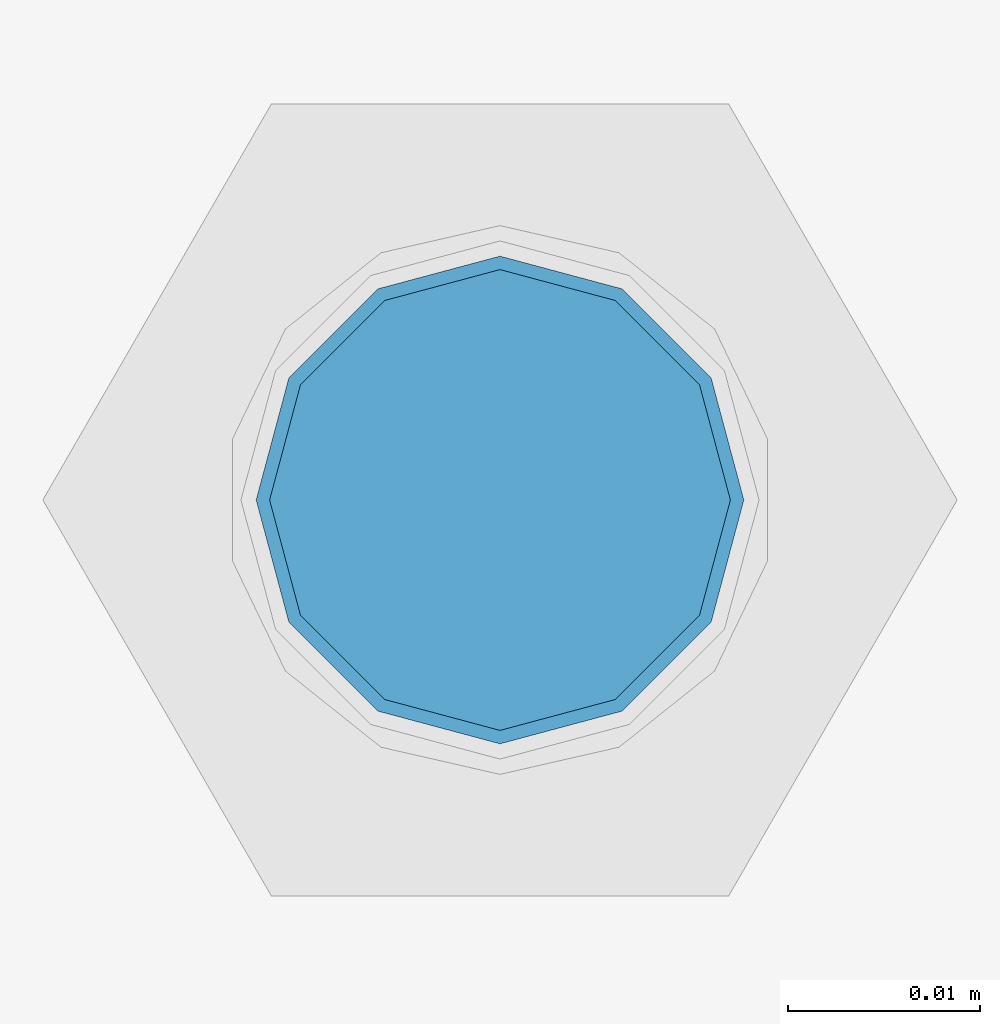
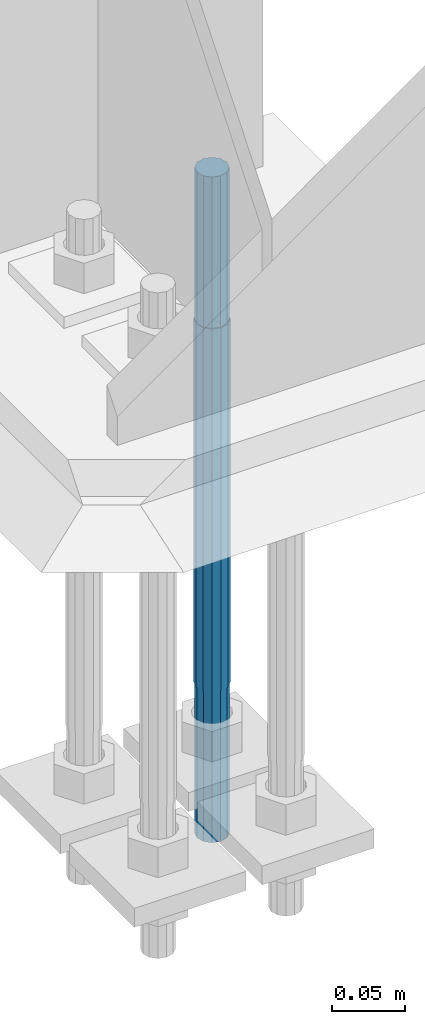
# One storey, part 1602 of 3843: 1 column, 1 element without a shape of its own.
"""IFC2X3 building model written with IfcOpenShell, lengths in millimetres."""

from ifc_helpers import new_model, si_unit, frame, origin_with_axes, place, context, subcontext, project, spatial, faceted_brep, material, type_object, element, aggregate, save


model = new_model("IFC2X3")

# Units and contexts
model_context = context("Model", 3, precision=1e-05, world=origin_with_axes())
body_context = subcontext(model_context, "Body", "Model", "MODEL_VIEW")
ifc_project = project(units=[si_unit("LENGTHUNIT", "METRE", prefix="MILLI"), si_unit("AREAUNIT", "SQUARE_METRE"), si_unit("VOLUMEUNIT", "CUBIC_METRE"), si_unit("MASSUNIT", "GRAM", prefix="KILO"), si_unit("TIMEUNIT", "SECOND"), si_unit("PLANEANGLEUNIT", "RADIAN"), si_unit("SOLIDANGLEUNIT", "STERADIAN"), si_unit("THERMODYNAMICTEMPERATUREUNIT", "DEGREE_CELSIUS"), si_unit("LUMINOUSINTENSITYUNIT", "LUMEN")], contexts=[model_context])

# Site, building, storey
site_placement = place(None, origin_with_axes())
site = spatial("IfcSite", under=ifc_project, at=site_placement, CompositionType="ELEMENT")
building_placement = place(site_placement, origin_with_axes())
building = spatial("IfcBuilding", under=site, at=building_placement, Name="Undefined", CompositionType="ELEMENT")
storey_placement = place(building_placement, origin_with_axes())
storey = spatial("IfcBuildingStorey", under=building, at=storey_placement, Name="Undefined", CompositionType="ELEMENT", Elevation=0.0)

# Assembly, column
assembly_placement = place(storey_placement, origin_with_axes())
assembly = element("IfcElementAssembly", 1, at=assembly_placement, inside=storey, Name="TEMPLATE", AssemblyPlace="NOTDEFINED", PredefinedType="RIGID_FRAME")
ifc_material = material(Name="Undefined/F1554-GR.55")
column_type = type_object("IfcColumnType", PredefinedType="NOTDEFINED")
column_placement = place(assembly_placement, frame((42113.2, 104609.9, 30022.8), z_axis=(0.0, 1.0, 0.0), x_axis=(0.0, 0.0, -1.0)))
column = element("IfcColumn", 2, at=column_placement, type_object=column_type, material=ifc_material, Name="ANCHOR_ROD", context=body_context, shape_type="Brep", body=[
    faceted_brep([(-127.0, -10.3923048454162, 6.0), (-127.0, -6.0, 10.3923048454126), (-127.0, 0.0, 12.0), (-127.0, 6.0, 10.3923048454126), (-127.0, 10.3923048454162, 6.0), (-127.0, 12.0, 0.0), (-127.0, 10.3923048454162, -6.0), (-127.0, 6.0, -10.3923048454126), (-127.0, 0.0, -12.0), (-127.0, -6.0, -10.3923048454126), (-127.0, -10.3923048454162, -6.0), (-127.0, -12.0, 0.0), (0.0, 12.0, 0.0), (0.0, 10.3923048454162, -6.0), (0.0, 6.0, -10.3923048454126), (0.0, 0.0, -12.0), (0.0, -6.0, -10.3923048454126), (0.0, -10.3923048454162, -6.0), (0.0, -12.0, 0.0), (0.0, -10.3923048454162, 6.0), (0.0, -6.0, 10.3923048454126), (0.0, 0.0, 12.0), (0.0, 6.0, 10.3923048454126), (0.0, 10.3923048454162, 6.0), (0.0, -10.9985226280696, 6.34999999999854), (0.0, -6.35000000000582, 10.9985226280623), (0.0, 0.0, 12.6999999999971), (0.0, 6.35000000000582, 10.9985226280623), (0.0, 10.9985226280696, 6.34999999999854), (0.0, 12.6999999999971, 0.0), (0.0, 10.9985226280696, -6.34999999999854), (0.0, 6.35000000000582, -10.9985226280623), (0.0, 0.0, -12.6999999999971), (0.0, -6.35000000000582, -10.9985226280623), (0.0, -10.9985226280696, -6.34999999999854), (0.0, -12.6999999999971, 0.0), (304.799999999999, -12.6999999999971, 0.0), (304.799999999999, -10.9985226280623, 6.35000000000036), (304.799999999999, -6.34999999999854, 10.9985226280623), (304.799999999999, 0.0, 12.7000000000007), (304.799999999999, 6.34999999999854, 10.9985226280623), (304.799999999999, 10.9985226280623, 6.35000000000036), (304.799999999999, 12.6999999999971, 0.0), (304.799999999999, 10.9985226280623, -6.35000000000036), (304.799999999999, 6.34999999999854, -10.9985226280623), (304.799999999999, 0.0, -12.7000000000007), (304.799999999999, -6.34999999999854, -10.9985226280623), (304.799999999999, -10.9985226280623, -6.35000000000036), (304.799999999999, -6.0, 10.3923048454126), (304.799999999999, 0.0, 12.0), (304.799999999999, 6.0, 10.3923048454126), (304.799999999999, 10.3923048454162, 6.0), (304.799999999999, 12.0, 0.0), (304.799999999999, 10.3923048454162, -6.0), (304.799999999999, 6.0, -10.3923048454126), (304.799999999999, 0.0, -12.0), (304.799999999999, -6.0, -10.3923048454126), (304.799999999999, -10.3923048454162, -6.0), (304.799999999999, -12.0, 0.0), (304.799999999999, -10.3923048454162, 6.0), (431.799999999999, -6.0, -10.3923048454126), (431.799999999999, 0.0, -12.0), (431.799999999999, 6.0, -10.3923048454126), (431.799999999999, 10.3923048454162, -6.0), (431.799999999999, 12.0, 0.0), (431.799999999999, 10.3923048454162, 6.0), (431.799999999999, 6.0, 10.3923048454126), (431.799999999999, 0.0, 12.0), (431.799999999999, -6.0, 10.3923048454126), (431.799999999999, -10.3923048454162, 6.0), (431.799999999999, -12.0, 0.0), (431.799999999999, -10.3923048454162, -6.0)], [[[0, 1, 2, 3, 4, 5, 6, 7, 8, 9, 10, 11]], [[6, 5, 12, 13]], [[7, 6, 13, 14]], [[8, 7, 14, 15]], [[9, 8, 15, 16]], [[10, 9, 16, 17]], [[11, 10, 17, 18]], [[0, 11, 18, 19]], [[1, 0, 19, 20]], [[2, 1, 20, 21]], [[3, 2, 21, 22]], [[4, 3, 22, 23]], [[5, 4, 23, 12]], [[24, 25, 26, 27, 28, 29, 30, 31, 32, 33, 34, 35], [22, 21, 20, 19, 18, 17, 16, 15, 14, 13, 12, 23]], [[24, 35, 36, 37]], [[25, 24, 37, 38]], [[26, 25, 38, 39]], [[27, 26, 39, 40]], [[28, 27, 40, 41]], [[29, 28, 41, 42]], [[30, 29, 42, 43]], [[31, 30, 43, 44]], [[32, 31, 44, 45]], [[33, 32, 45, 46]], [[34, 33, 46, 47]], [[35, 34, 47, 36]], [[46, 45, 44, 43, 42, 41, 40, 39, 38, 37, 36, 47], [48, 49, 50, 51, 52, 53, 54, 55, 56, 57, 58, 59]], [[60, 61, 62, 63, 64, 65, 66, 67, 68, 69, 70, 71]], [[68, 67, 49, 48]], [[69, 68, 48, 59]], [[70, 69, 59, 58]], [[71, 70, 58, 57]], [[60, 71, 57, 56]], [[61, 60, 56, 55]], [[62, 61, 55, 54]], [[63, 62, 54, 53]], [[64, 63, 53, 52]], [[65, 64, 52, 51]], [[66, 65, 51, 50]], [[67, 66, 50, 49]]]),
])
aggregate(assembly, [column])

save(model, "model.ifc")
